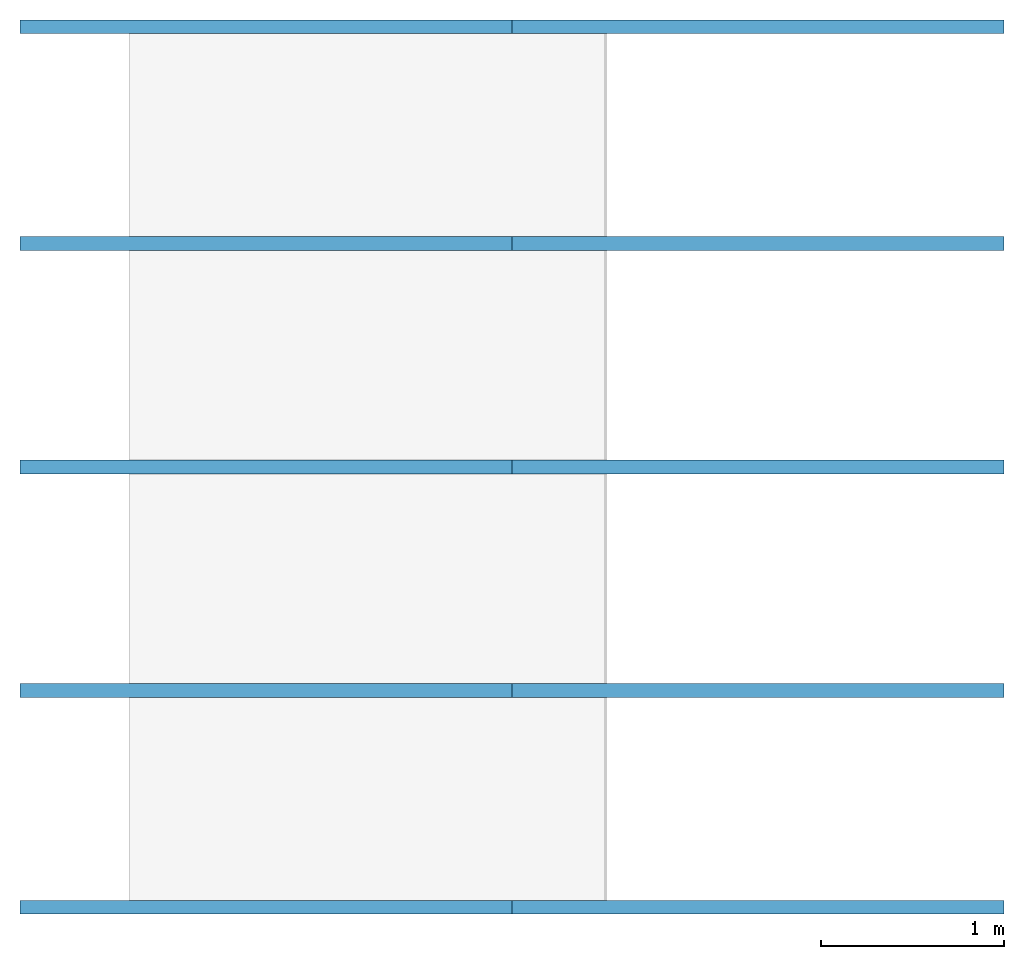
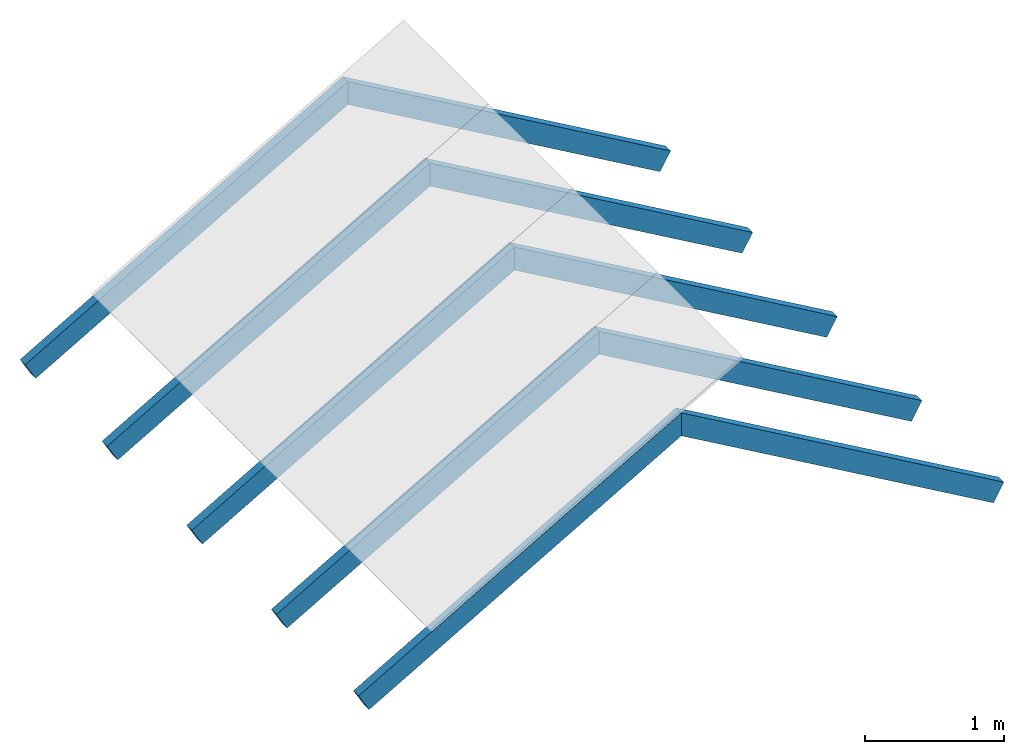
# One storey, part 1 of 2: 10 beams.
"""IFC4 building model written with IfcOpenShell, lengths in millimetres."""

from ifc_helpers import new_model, entity, si_unit, converted_unit, frame, frame_2d, origin_with_axes, place, context, subcontext, project, spatial, rectangle, extrude, clip, halfspace, material, material_profile, profile_set, profile_usage, type_object, element, save


model = new_model("IFC4")

# Units and contexts
model_context = context("Model", 3, precision=1e-05, world=origin_with_axes())
plan_context = context("Plan", 2, precision=1e-05, world=frame_2d((0.0, 0.0, 0.0), x_axis=(1.0, 0.0, 0.0)))
body_context = subcontext(model_context, "Body", "Model", "MODEL_VIEW")
ifc_project = project(units=[converted_unit("PLANEANGLEUNIT", "degree", entity("IfcReal", 0.0174532925199433), si_unit("PLANEANGLEUNIT", "RADIAN"), dimensions=[0, 0, 0, 0, 0, 0, 0]), si_unit("AREAUNIT", "SQUARE_METRE", prefix="MILLI"), si_unit("VOLUMEUNIT", "CUBIC_METRE", prefix="MILLI"), si_unit("LENGTHUNIT", "METRE", prefix="MILLI")], contexts=[model_context, plan_context])

# Site, building, storey
site_placement = place(None, origin_with_axes())
site = spatial("IfcSite", under=ifc_project, at=site_placement)
building_placement = place(site_placement, origin_with_axes())
building = spatial("IfcBuilding", under=site, at=building_placement, Name="Building")
storey_placement = place(building_placement, origin_with_axes())
storey = spatial("IfcBuildingStorey", under=building, at=storey_placement, Name="Storey")

# Beams
ifc_material = material(Name="vuren")
ifc_material_profile = material_profile(ifc_material, rectangle(XDim=75.0, YDim=175.0))
ifc_profile_set = profile_set([ifc_material_profile])
ifc_profile_usage_1 = profile_usage(ifc_profile_set, cardinal=1)
beam_type = type_object("IfcBeamType", Name="75x175mm", PredefinedType="BEAM", material=ifc_profile_set)
beam_1_placement = place(storey_placement, frame((0.0, 0.0, 0.0), z_axis=(0.866025507450104, 1.30204497850173e-07, 0.49999988079071), x_axis=(-1.62920684942947e-07, 1.0, 2.1777914582799e-08)))
element("IfcBeam", 1, at=beam_1_placement, inside=storey, type_object=beam_type, material=ifc_profile_usage_1, Name="Beam", PredefinedType="NOTDEFINED", context=body_context, shape_type="Clipping", body=[
    clip(extrude(rectangle(XDim=75.0, YDim=175.0), frame((-37.5, 87.5, 0.0), z_axis=(0.0, 0.0, 1.0), x_axis=(1.0, 0.0, 0.0)), (0.0, 0.0, 1.0), 3377.0732516296), halfspace(frame((0.00133808077862341, 174.999952316284, 3101.03631019592), z_axis=(4.33125791232669e-07, -0.500000894069672, 0.866024911403656), x_axis=(-1.25016100582798e-07, -0.866024911403656, -0.500000894069672)), False)),
])
ifc_profile_usage_2 = profile_usage(ifc_profile_set)
beam_2_placement = place(storey_placement, frame((-43.7501296401024, 1144.99974250793, 75.7773220539093), z_axis=(0.866026103496552, 1.60038197805079e-07, 0.499999791383743), x_axis=(-2.82129974493728e-07, 1.0, 1.68587476423454e-07)))
element("IfcBeam", 2, at=beam_2_placement, inside=storey, type_object=beam_type, material=ifc_profile_usage_2, Name="Beam", PredefinedType="NOTDEFINED", context=body_context, shape_type="Clipping", body=[
    clip(extrude(rectangle(XDim=75.0, YDim=175.0), origin_with_axes(), (0.0, 0.0, 1.0), 3326.55487274688), halfspace(frame((-999.99862909317, 87.4999538064003, 3101.03702545166), z_axis=(4.33126075449763e-07, -0.499998867511749, 0.866026103496552), x_axis=(-1.25017109553482e-07, -0.866026103496552, -0.499998867511749)), False)),
])
ifc_profile_usage_3 = profile_usage(ifc_profile_set)
beam_3_placement = place(storey_placement, frame((-43.7512435019016, 2364.99929428101, 75.7777988910675), z_axis=(0.866025865077972, 3.97368381754859e-07, 0.499999672174454), x_axis=(-5.2054855359529e-07, 1.0, 1.06880271744103e-07)))
element("IfcBeam", 3, at=beam_3_placement, inside=storey, type_object=beam_type, material=ifc_profile_usage_3, Name="Beam", PredefinedType="NOTDEFINED", context=body_context, shape_type="Clipping", body=[
    clip(extrude(rectangle(XDim=75.0, YDim=175.0), origin_with_axes(), (0.0, 0.0, 1.0), 3326.55487274689), halfspace(frame((-1999.99868869781, 87.4998196959496, 3101.03702545166), z_axis=(4.33126217558311e-07, -0.499997824430466, 0.866026699542999), x_axis=(-1.25016242691345e-07, -0.866026699542999, -0.499997824430466)), False)),
])
ifc_profile_usage_4 = profile_usage(ifc_profile_set, cardinal=1)
beam_4_placement = place(storey_placement, frame((-0.00044947032051823, 3622.49946594238, -1.25953842911031e-05), z_axis=(0.866025745868683, 2.96953345468864e-07, 0.499999731779099), x_axis=(-4.01339264044509e-07, 1.0, 1.01233602833872e-07)))
element("IfcBeam", 4, at=beam_4_placement, inside=storey, type_object=beam_type, material=ifc_profile_usage_4, Name="Beam", PredefinedType="NOTDEFINED", context=body_context, shape_type="Clipping", body=[
    clip(extrude(rectangle(XDim=75.0, YDim=175.0), frame((-37.5, 87.5, 0.0), z_axis=(0.0, 0.0, 1.0), x_axis=(1.0, 0.0, 0.0)), (0.0, 0.0, 1.0), 3377.07275743536), halfspace(frame((-2999.99856948853, 174.99965429306, 3101.0377407074), z_axis=(4.33126075449763e-07, -0.499998867511749, 0.866026103496552), x_axis=(-1.25016043739379e-07, -0.866026103496552, -0.499998867511749)), False)),
])
ifc_profile_usage_5 = profile_usage(ifc_profile_set, cardinal=1)
beam_5_placement = place(storey_placement, frame((-0.00119606124826532, 4804.99887466431, 0.00026307679945603), z_axis=(0.866025745868683, 3.15203436684897e-07, 0.499999731779099), x_axis=(-4.01339264044509e-07, 1.0, 6.47333564529617e-08)))
element("IfcBeam", 5, at=beam_5_placement, inside=storey, type_object=beam_type, material=ifc_profile_usage_5, Name="Beam", PredefinedType="NOTDEFINED", context=body_context, shape_type="Clipping", body=[
    clip(extrude(rectangle(XDim=75.0, YDim=175.0), frame((-37.5, 87.5, 0.0), z_axis=(0.0, 0.0, 1.0), x_axis=(1.0, 0.0, 0.0)), (0.0, 0.0, 1.0), 3377.07325162961), halfspace(frame((-3999.99856948853, 174.999639391899, 3101.03797912598), z_axis=(4.33125791232669e-07, -0.500000894069672, 0.866024911403656), x_axis=(-1.25016669016986e-07, -0.866024911403656, -0.500000894069672)), False)),
])
ifc_profile_usage_6 = profile_usage(ifc_profile_set, cardinal=1)
beam_6_placement = place(storey_placement, frame((5196.15316390991, -74.9983787536621, 0.0), z_axis=(-0.866025507450104, -4.12391415238744e-07, 0.49999988079071), x_axis=(4.8876205482884e-07, -1.0, 2.1777914582799e-08)))
element("IfcBeam", 6, at=beam_6_placement, inside=storey, type_object=beam_type, material=ifc_profile_usage_6, Name="Beam", PredefinedType="NOTDEFINED", context=body_context, shape_type="Clipping", body=[
    clip(extrude(rectangle(XDim=75.0, YDim=175.0), frame((-37.5, 87.5, 0.0), z_axis=(0.0, 0.0, 1.0), x_axis=(1.0, 0.0, 0.0)), (0.0, 0.0, 1.0), 3377.07311043151), halfspace(frame((-75.0013440847397, 174.999952316284, 3101.03631019592), z_axis=(1.07284478190195e-07, -0.499998867511749, 0.866026103496552), x_axis=(8.1459880618695e-08, -0.866026103496552, -0.499998867511749)), False)),
])
ifc_profile_usage_7 = profile_usage(ifc_profile_set, cardinal=1)
beam_7_placement = place(storey_placement, frame((5196.15650177002, 1107.50186443329, -0.000648971024475031), z_axis=(-0.866026043891907, -4.43146547013384e-07, 0.500000178813934), x_axis=(5.52335052361741e-07, -1.0, 7.03799258872095e-08)))
element("IfcBeam", 7, at=beam_7_placement, inside=storey, type_object=beam_type, material=ifc_profile_usage_7, Name="Beam", PredefinedType="NOTDEFINED", context=body_context, shape_type="Clipping", body=[
    clip(extrude(rectangle(XDim=75.0, YDim=175.0), frame((-37.5, 87.5, 0.0), z_axis=(0.0, 0.0, 1.0), x_axis=(1.0, 0.0, 0.0)), (0.0, 0.0, 1.0), 3377.07261623723), halfspace(frame((962.498724460602, 174.999952316284, 3101.0365486145), z_axis=(1.07284648720452e-07, -0.500000894069672, 0.866024911403656), x_axis=(8.14616498701071e-08, -0.866024911403656, -0.500000894069672)), False)),
])
ifc_profile_usage_8 = profile_usage(ifc_profile_set)
beam_8_placement = place(storey_placement, frame((5239.90392684937, 2365.00072479248, 75.7772997021675), z_axis=(-0.866025805473328, -4.43146461748256e-07, 0.500000059604645), x_axis=(5.52335052361741e-07, -1.0, 7.03799258872095e-08)))
element("IfcBeam", 8, at=beam_8_placement, inside=storey, type_object=beam_type, material=ifc_profile_usage_8, Name="Beam", PredefinedType="NOTDEFINED", context=body_context, shape_type="Clipping", body=[
    clip(extrude(rectangle(XDim=75.0, YDim=175.0), origin_with_axes(), (0.0, 0.0, 1.0), 3326.55458606178), halfspace(frame((1999.99892711639, 87.4998569488525, 3101.03678703308), z_axis=(1.07284741091007e-07, -0.500001907348633, 0.866024315357208), x_axis=(8.14611595956194e-08, -0.866024315357208, -0.500001907348633)), False)),
])
ifc_profile_usage_9 = profile_usage(ifc_profile_set)
beam_9_placement = place(storey_placement, frame((5239.90345001221, 3585.00123023987, 75.7771655917168), z_axis=(-0.866025626659393, -4.43146348061418e-07, 0.499999940395355), x_axis=(5.52335052361741e-07, -1.0, 7.03799258872095e-08)))
element("IfcBeam", 9, at=beam_9_placement, inside=storey, type_object=beam_type, material=ifc_profile_usage_9, Name="Beam", PredefinedType="NOTDEFINED", context=body_context, shape_type="Clipping", body=[
    clip(extrude(rectangle(XDim=75.0, YDim=175.0), origin_with_axes(), (0.0, 0.0, 1.0), 3326.55498025405), halfspace(frame((2962.49890327454, 87.5002145767212, 3101.03678703308), z_axis=(1.07284648720452e-07, -0.500000894069672, 0.866024911403656), x_axis=(8.14605840560034e-08, -0.866024911403656, -0.500000894069672)), False)),
])
ifc_profile_usage_10 = profile_usage(ifc_profile_set, cardinal=1)
beam_10_placement = place(storey_placement, frame((5196.1522102356, 4730.00049591064, 0.000263076685769192), z_axis=(-0.866025626659393, -4.43146348061418e-07, 0.499999940395355), x_axis=(5.52335052361741e-07, -1.0, 7.03799258872095e-08)))
element("IfcBeam", 10, at=beam_10_placement, inside=storey, type_object=beam_type, material=ifc_profile_usage_10, Name="Beam", PredefinedType="NOTDEFINED", context=body_context, shape_type="Clipping", body=[
    clip(extrude(rectangle(XDim=75.0, YDim=175.0), frame((-37.5, 87.5, 0.0), z_axis=(0.0, 0.0, 1.0), x_axis=(1.0, 0.0, 0.0)), (0.0, 0.0, 1.0), 3377.07311043144), halfspace(frame((3924.99899864197, 175.000429153442, 3101.03607177734), z_axis=(1.07284478190195e-07, -0.499998867511749, 0.866026103496552), x_axis=(8.14604419474563e-08, -0.866026103496552, -0.499998867511749)), False)),
])

save(model, "model.ifc")
